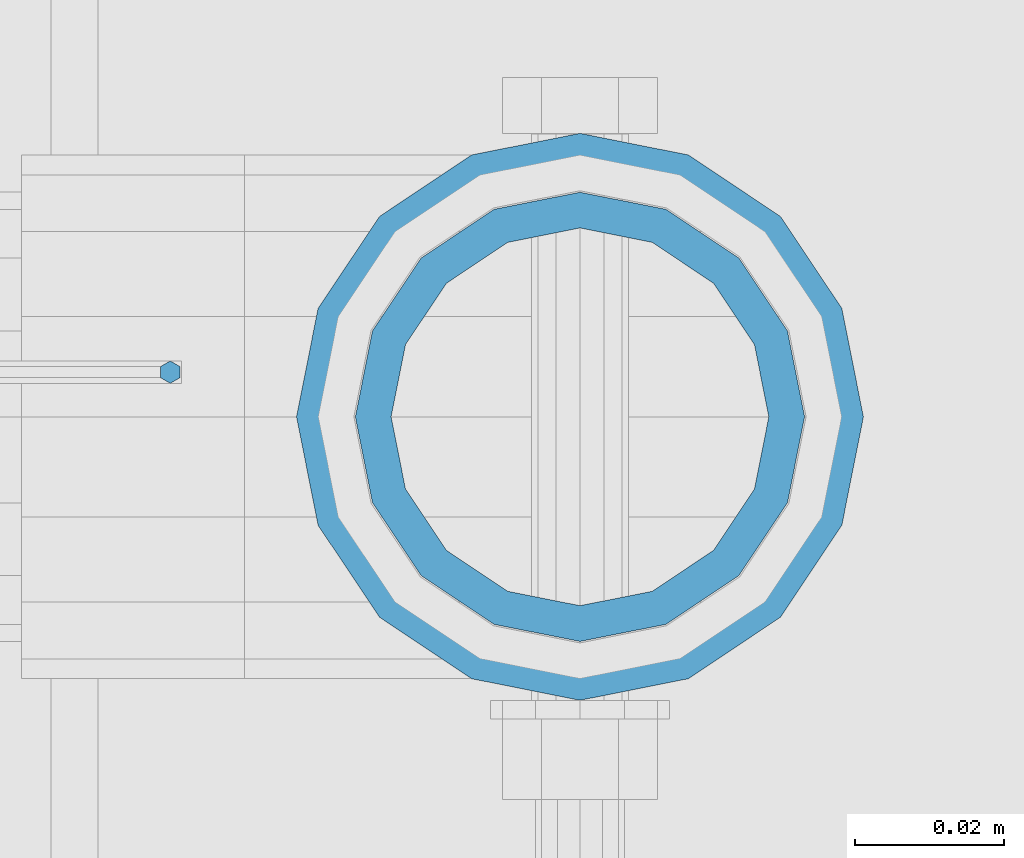
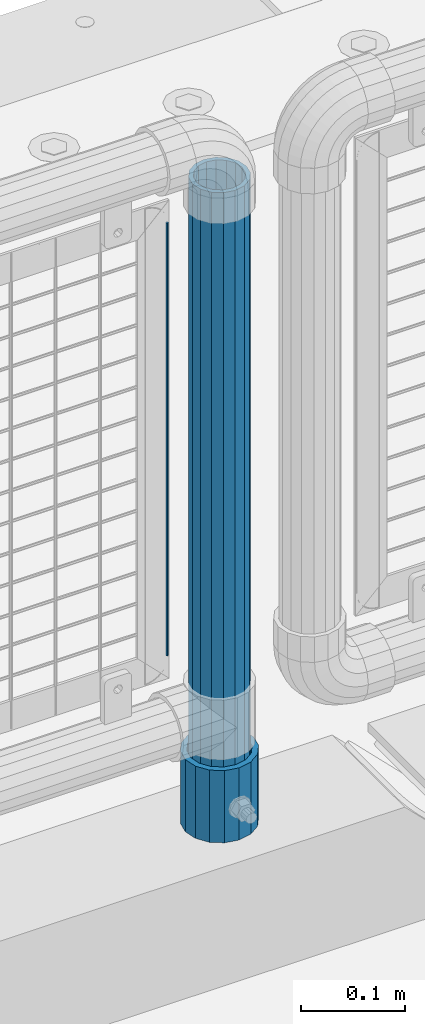
# One storey, part 96 of 257: 3 columns.
"""IFC2X3 building model written with IfcOpenShell, lengths in millimetres."""

from ifc_helpers import new_model, si_unit, frame, origin_with_axes, place, context, subcontext, project, spatial, faceted_brep, material, type_object, element, save


model = new_model("IFC2X3")

# Units and contexts
model_context = context("Model", 3, precision=1e-05, world=origin_with_axes())
body_context = subcontext(model_context, "Body", "Model", "MODEL_VIEW")
ifc_project = project(units=[si_unit("LENGTHUNIT", "METRE", prefix="MILLI"), si_unit("AREAUNIT", "SQUARE_METRE"), si_unit("VOLUMEUNIT", "CUBIC_METRE"), si_unit("MASSUNIT", "GRAM", prefix="KILO"), si_unit("TIMEUNIT", "SECOND"), si_unit("PLANEANGLEUNIT", "RADIAN"), si_unit("SOLIDANGLEUNIT", "STERADIAN"), si_unit("THERMODYNAMICTEMPERATUREUNIT", "DEGREE_CELSIUS"), si_unit("LUMINOUSINTENSITYUNIT", "LUMEN")], contexts=[model_context])

# Site, building, storey
site_placement = place(None, origin_with_axes())
site = spatial("IfcSite", under=ifc_project, at=site_placement, CompositionType="ELEMENT")
building_placement = place(site_placement, origin_with_axes())
building = spatial("IfcBuilding", under=site, at=building_placement, Name="Standard", CompositionType="ELEMENT")
storey_placement = place(building_placement, origin_with_axes())
storey = spatial("IfcBuildingStorey", under=building, at=storey_placement, Name="Undefined", CompositionType="ELEMENT", Elevation=0.0)

# Columns
ifc_material_1 = material()
column_type_1 = type_object("IfcColumnType", PredefinedType="NOTDEFINED")
column_1_placement = place(storey_placement, frame((57470.9999998042, 10664.5, 168.019999999998), z_axis=(0.0, 1.0, 0.0), x_axis=(0.0, 0.0, 1.0)))
element("IfcColumn", 1, at=column_1_placement, inside=storey, type_object=column_type_1, material=ifc_material_1, context=body_context, shape_type="Brep", body=[
    faceted_brep([(0.0, -31.75, 0.0), (0.0, -29.3331751572332, 12.1501989775916), (85.0, -29.3331751572332, 12.1501989775916), (85.0, -31.75, 0.0), (0.0, -22.4506403026753, 22.4506403026735), (85.0, -22.4506403026753, 22.4506403026735), (0.0, -12.1501989775934, 29.3331751572332), (85.0, -12.1501989775934, 29.3331751572332), (0.0, 0.0, 31.75), (85.0, 0.0, 31.75), (0.0, 12.1501989775934, 29.3331751572332), (85.0, 12.1501989775934, 29.3331751572332), (0.0, 22.4506403026753, 22.4506403026735), (85.0, 22.4506403026753, 22.4506403026735), (0.0, 29.3331751572332, 12.1501989775916), (85.0, 29.3331751572332, 12.1501989775916), (0.0, 31.75, 0.0), (85.0, 31.75, 0.0), (0.0, 29.3331751572332, -12.1501989775916), (85.0, 29.3331751572332, -12.1501989775916), (0.0, 22.4506403026753, -22.4506403026735), (85.0, 22.4506403026753, -22.4506403026735), (0.0, 12.1501989775934, -29.3331751572332), (85.0, 12.1501989775934, -29.3331751572332), (0.0, 0.0, -31.75), (85.0, 0.0, -31.75), (0.0, -12.1501989775934, -29.3331751572332), (85.0, -12.1501989775934, -29.3331751572332), (0.0, -22.4506403026753, -22.4506403026735), (85.0, -22.4506403026753, -22.4506403026735), (0.0, -29.3331751572332, -12.1501989775916), (85.0, -29.3331751572332, -12.1501989775916), (0.0, -38.0500000000029, 0.0), (0.0, -35.1536162120537, -14.561104601491), (85.0, -35.1536162120537, -14.561104601491), (85.0, -38.0500000000029, 0.0), (0.0, -26.9054130241493, -26.9054130241475), (85.0, -26.9054130241493, -26.9054130241475), (0.0, -14.5611046014892, -35.1536162120537), (85.0, -14.5611046014892, -35.1536162120537), (0.0, 0.0, -38.0499999999993), (85.0, 0.0, -38.0499999999993), (0.0, 14.5611046014892, -35.1536162120537), (85.0, 14.5611046014892, -35.1536162120537), (0.0, 26.9054130241493, -26.9054130241475), (85.0, 26.9054130241493, -26.9054130241475), (0.0, 35.1536162120537, -14.561104601491), (85.0, 35.1536162120537, -14.561104601491), (0.0, 38.0500000000029, 0.0), (85.0, 38.0500000000029, 0.0), (0.0, 35.1536162120537, 14.561104601491), (85.0, 35.1536162120537, 14.561104601491), (0.0, 26.9054130241493, 26.9054130241475), (85.0, 26.9054130241493, 26.9054130241475), (0.0, 14.5611046014892, 35.1536162120537), (85.0, 14.5611046014892, 35.1536162120537), (0.0, 0.0, 38.0499999999993), (85.0, 0.0, 38.0499999999993), (0.0, -14.5611046014892, 35.1536162120537), (85.0, -14.5611046014892, 35.1536162120537), (0.0, -26.9054130241493, 26.9054130241475), (85.0, -26.9054130241493, 26.9054130241475), (0.0, -35.1536162120537, 14.561104601491), (85.0, -35.1536162120537, 14.561104601491)], [[[0, 1, 2, 3]], [[1, 4, 5, 2]], [[4, 6, 7, 5]], [[6, 8, 9, 7]], [[8, 10, 11, 9]], [[10, 12, 13, 11]], [[12, 14, 15, 13]], [[14, 16, 17, 15]], [[16, 18, 19, 17]], [[18, 20, 21, 19]], [[20, 22, 23, 21]], [[22, 24, 25, 23]], [[24, 26, 27, 25]], [[26, 28, 29, 27]], [[28, 30, 31, 29]], [[30, 0, 3, 31]], [[32, 33, 34, 35]], [[33, 36, 37, 34]], [[36, 38, 39, 37]], [[38, 40, 41, 39]], [[40, 42, 43, 41]], [[42, 44, 45, 43]], [[44, 46, 47, 45]], [[46, 48, 49, 47]], [[48, 50, 51, 49]], [[50, 52, 53, 51]], [[52, 54, 55, 53]], [[54, 56, 57, 55]], [[56, 58, 59, 57]], [[58, 60, 61, 59]], [[60, 62, 63, 61]], [[62, 32, 35, 63]], [[37, 39, 41, 43, 45, 47, 49, 51, 53, 55, 57, 59, 61, 63, 35, 34], [5, 7, 9, 11, 13, 15, 17, 19, 21, 23, 25, 27, 29, 31, 3, 2]], [[62, 60, 58, 56, 54, 52, 50, 48, 46, 44, 42, 40, 38, 36, 33, 32], [30, 28, 26, 24, 22, 20, 18, 16, 14, 12, 10, 8, 6, 4, 1, 0]]]),
])
column_type_2 = type_object("IfcColumnType", PredefinedType="NOTDEFINED")
column_2_placement = place(storey_placement, frame((57470.9999998042, 10664.5, 168.019999999998), z_axis=(-1.0, 0.0, 0.0), x_axis=(0.0, 0.0, 1.0)))
element("IfcColumn", 2, at=column_2_placement, inside=storey, type_object=column_type_2, material=ifc_material_1, context=body_context, shape_type="Brep", body=[
    faceted_brep([(0.0, -25.3500000000004, 0.0), (0.0, -23.4203461491616, 9.70102501045767), (760.0, -23.4203461491616, 9.70102501045767), (760.0, -25.3500000000004, 0.0), (0.0, -17.9251569030785, 17.9251569030821), (760.0, -17.9251569030785, 17.9251569030821), (0.0, -9.70102501045585, 23.4203461491634), (760.0, -9.70102501045585, 23.4203461491634), (0.0, 0.0, 25.3499999999985), (760.0, 0.0, 25.3499999999985), (0.0, 9.70102501045585, 23.4203461491634), (760.0, 9.70102501045585, 23.4203461491634), (0.0, 17.9251569030785, 17.9251569030821), (760.0, 17.9251569030785, 17.9251569030821), (0.0, 23.4203461491616, 9.70102501045767), (760.0, 23.4203461491616, 9.70102501045767), (0.0, 25.3500000000004, 0.0), (760.0, 25.3500000000004, 0.0), (0.0, 23.4203461491616, -9.70102501045767), (760.0, 23.4203461491616, -9.70102501045767), (0.0, 17.9251569030785, -17.9251569030821), (760.0, 17.9251569030785, -17.9251569030821), (0.0, 9.70102501045585, -23.4203461491634), (760.0, 9.70102501045585, -23.4203461491634), (0.0, 0.0, -25.3499999999985), (760.0, 0.0, -25.3499999999985), (0.0, -9.70102501045585, -23.4203461491634), (760.0, -9.70102501045585, -23.4203461491634), (0.0, -17.9251569030785, -17.9251569030821), (760.0, -17.9251569030785, -17.9251569030821), (0.0, -23.4203461491616, -9.70102501045767), (760.0, -23.4203461491616, -9.70102501045767), (0.0, -30.1499999999996, 0.0), (0.0, -27.8549679052157, -11.5379054858058), (760.0, -27.8549679052157, -11.5379054858058), (760.0, -30.1499999999996, 0.0), (0.0, -21.3192694527752, -21.3192694527752), (760.0, -21.3192694527752, -21.3192694527752), (0.0, -11.5379054858076, -27.8549679052157), (760.0, -11.5379054858076, -27.8549679052157), (0.0, 0.0, -30.1500000000015), (760.0, 0.0, -30.1500000000015), (0.0, 11.5379054858076, -27.8549679052157), (760.0, 11.5379054858076, -27.8549679052157), (0.0, 21.3192694527752, -21.3192694527752), (760.0, 21.3192694527752, -21.3192694527752), (0.0, 27.8549679052157, -11.5379054858058), (760.0, 27.8549679052157, -11.5379054858058), (0.0, 30.1499999999996, 0.0), (760.0, 30.1499999999996, 0.0), (0.0, 27.8549679052157, 11.5379054858058), (760.0, 27.8549679052157, 11.5379054858058), (0.0, 21.3192694527752, 21.3192694527752), (760.0, 21.3192694527752, 21.3192694527752), (0.0, 11.5379054858076, 27.8549679052157), (760.0, 11.5379054858076, 27.8549679052157), (0.0, 0.0, 30.1500000000015), (760.0, 0.0, 30.1500000000015), (0.0, -11.5379054858076, 27.8549679052157), (760.0, -11.5379054858076, 27.8549679052157), (0.0, -21.3192694527752, 21.3192694527752), (760.0, -21.3192694527752, 21.3192694527752), (0.0, -27.8549679052157, 11.5379054858058), (760.0, -27.8549679052157, 11.5379054858058)], [[[0, 1, 2, 3]], [[1, 4, 5, 2]], [[4, 6, 7, 5]], [[6, 8, 9, 7]], [[8, 10, 11, 9]], [[10, 12, 13, 11]], [[12, 14, 15, 13]], [[14, 16, 17, 15]], [[16, 18, 19, 17]], [[18, 20, 21, 19]], [[20, 22, 23, 21]], [[22, 24, 25, 23]], [[24, 26, 27, 25]], [[26, 28, 29, 27]], [[28, 30, 31, 29]], [[30, 0, 3, 31]], [[32, 33, 34, 35]], [[33, 36, 37, 34]], [[36, 38, 39, 37]], [[38, 40, 41, 39]], [[40, 42, 43, 41]], [[42, 44, 45, 43]], [[44, 46, 47, 45]], [[46, 48, 49, 47]], [[48, 50, 51, 49]], [[50, 52, 53, 51]], [[52, 54, 55, 53]], [[54, 56, 57, 55]], [[56, 58, 59, 57]], [[58, 60, 61, 59]], [[60, 62, 63, 61]], [[62, 32, 35, 63]], [[37, 39, 41, 43, 45, 47, 49, 51, 53, 55, 57, 59, 61, 63, 35, 34], [5, 7, 9, 11, 13, 15, 17, 19, 21, 23, 25, 27, 29, 31, 3, 2]], [[62, 60, 58, 56, 54, 52, 50, 48, 46, 44, 42, 40, 38, 36, 33, 32], [30, 28, 26, 24, 22, 20, 18, 16, 14, 12, 10, 8, 6, 4, 1, 0]]]),
])
ifc_material_2 = material(Name="Misc_Undefined")
column_type_3 = type_object("IfcColumnType", Name="D3", PredefinedType="NOTDEFINED")
column_3_placement = place(storey_placement, frame((57416.0, 10670.5, 378.020000000006), z_axis=(-1.0, 0.0, 0.0), x_axis=(0.0, 0.0, 1.0)))
element("IfcColumn", 3, at=column_3_placement, inside=storey, type_object=column_type_3, material=ifc_material_2, ObjectType="D3", context=body_context, shape_type="Brep", body=[
    faceted_brep([(0.0, -1.5, -5.6843418860808e-14), (0.0, -0.750000000001819, -1.29903810567669), (510.0, -0.75, -1.29903810567339), (510.0, -1.5, 0.0), (7.27595761418343e-12, 0.749999999998181, -1.29903810567669), (510.0, 0.75, -1.29903810567339), (0.0, 1.5, -5.6843418860808e-14), (510.0, 1.5, 0.0), (7.27595761418343e-12, 0.749999999998181, 1.29903810567669), (510.0, 0.75, 1.29903810567339), (0.0, -0.750000000001819, 1.29903810567669), (510.0, -0.75, 1.29903810567339)], [[[0, 1, 2, 3]], [[1, 4, 5, 2]], [[4, 6, 7, 5]], [[6, 8, 9, 7]], [[8, 10, 11, 9]], [[10, 0, 3, 11]], [[5, 7, 9, 11, 3, 2]], [[10, 8, 6, 4, 1, 0]]]),
])

save(model, "model.ifc")
